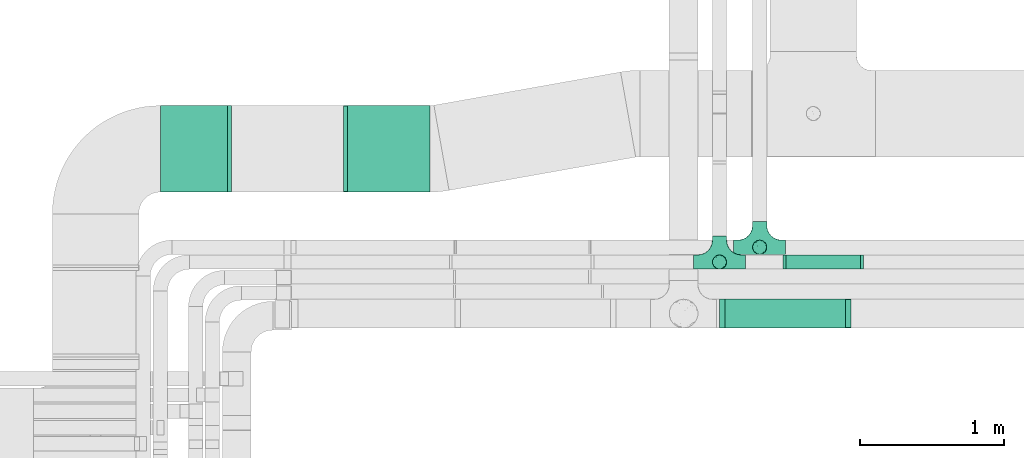
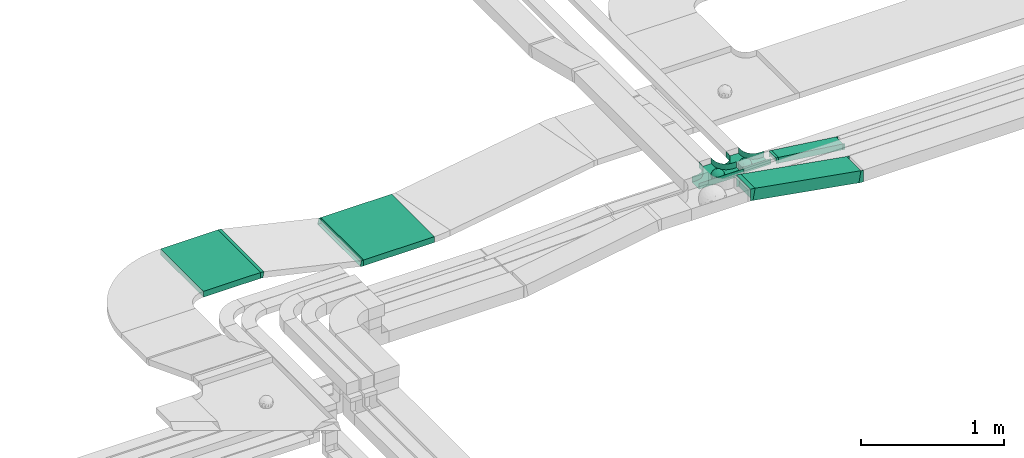
# One storey, part 9 of 28: 8 flow fittings, 4 flow segments.
"""IFC2X3 building model written with IfcOpenShell, lengths in millimetres."""

from ifc_helpers import new_model, entity, si_unit, converted_unit, derived_unit, direction, frame, frame_2d, origin, origin_2d_with_axis, place, context, subcontext, project, spatial, rectangle, extrude, faceted_brep, source, transform, mapped, material, material_list, type_object, type_shapes, element, save


model = new_model("IFC2X3")

# Units and contexts
model_context = context("Model", 3, precision=0.01, world=origin(), true_north=direction((6.12303176911189e-17, 1.0)))
body_context = subcontext(model_context, "Body", "Model", "MODEL_VIEW")
ifc_project = project(units=[si_unit("LENGTHUNIT", "METRE", prefix="MILLI"), si_unit("AREAUNIT", "SQUARE_METRE"), si_unit("VOLUMEUNIT", "CUBIC_METRE"), converted_unit("PLANEANGLEUNIT", "DEGREE", entity("IfcRatioMeasure", 0.0174532925199433), si_unit("PLANEANGLEUNIT", "RADIAN"), dimensions=[0, 0, 0, 0, 0, 0, 0]), si_unit("MASSUNIT", "GRAM", prefix="KILO"), derived_unit("MASSDENSITYUNIT", [(si_unit("MASSUNIT", "GRAM", prefix="KILO"), 1), (si_unit("LENGTHUNIT", "METRE"), -3)]), derived_unit("MOMENTOFINERTIAUNIT", [(si_unit("LENGTHUNIT", "METRE"), 4)]), si_unit("TIMEUNIT", "SECOND"), si_unit("FREQUENCYUNIT", "HERTZ"), si_unit("THERMODYNAMICTEMPERATUREUNIT", "DEGREE_CELSIUS"), derived_unit("THERMALTRANSMITTANCEUNIT", [(si_unit("MASSUNIT", "GRAM", prefix="KILO"), 1), (si_unit("THERMODYNAMICTEMPERATUREUNIT", "KELVIN"), -1), (si_unit("TIMEUNIT", "SECOND"), -3)]), derived_unit("VOLUMETRICFLOWRATEUNIT", [(si_unit("LENGTHUNIT", "METRE"), 3), (si_unit("TIMEUNIT", "SECOND"), -1)]), derived_unit("MASSFLOWRATEUNIT", [(si_unit("MASSUNIT", "GRAM", prefix="KILO"), 1), (si_unit("TIMEUNIT", "SECOND"), -1)]), derived_unit("ROTATIONALFREQUENCYUNIT", [(si_unit("TIMEUNIT", "SECOND"), -1)]), si_unit("ELECTRICCURRENTUNIT", "AMPERE"), si_unit("ELECTRICVOLTAGEUNIT", "VOLT"), si_unit("POWERUNIT", "WATT"), si_unit("FORCEUNIT", "NEWTON", prefix="KILO"), si_unit("ILLUMINANCEUNIT", "LUX"), si_unit("LUMINOUSFLUXUNIT", "LUMEN"), si_unit("LUMINOUSINTENSITYUNIT", "CANDELA"), derived_unit("USERDEFINED", [(si_unit("MASSUNIT", "GRAM", prefix="KILO"), -1), (si_unit("LENGTHUNIT", "METRE"), -2), (si_unit("TIMEUNIT", "SECOND"), 3), (si_unit("LUMINOUSFLUXUNIT", "LUMEN"), 1)]), derived_unit("LINEARVELOCITYUNIT", [(si_unit("LENGTHUNIT", "METRE"), 1), (si_unit("TIMEUNIT", "SECOND"), -1)]), si_unit("PRESSUREUNIT", "PASCAL"), derived_unit("USERDEFINED", [(si_unit("LENGTHUNIT", "METRE"), -2), (si_unit("MASSUNIT", "GRAM", prefix="KILO"), 1), (si_unit("TIMEUNIT", "SECOND"), -2)]), derived_unit("LINEARFORCEUNIT", [(si_unit("MASSUNIT", "GRAM", prefix="KILO"), 1), (si_unit("LENGTHUNIT", "METRE"), 1), (si_unit("TIMEUNIT", "SECOND"), -2), (si_unit("LENGTHUNIT", "METRE"), -1)]), derived_unit("PLANARFORCEUNIT", [(si_unit("MASSUNIT", "GRAM", prefix="KILO"), 1), (si_unit("LENGTHUNIT", "METRE"), 1), (si_unit("TIMEUNIT", "SECOND"), -2), (si_unit("LENGTHUNIT", "METRE"), -2)])], contexts=[model_context])

# Site, building, storey
site_placement = place(None, origin())
site = spatial("IfcSite", under=ifc_project, at=site_placement, CompositionType="ELEMENT")
building_placement = place(site_placement, origin())
building = spatial("IfcBuilding", under=site, at=building_placement, CompositionType="ELEMENT")
storey_placement = place(building_placement, frame((0.0, 0.0, 4200.0)))
storey = spatial("IfcBuildingStorey", under=building, at=storey_placement, CompositionType="ELEMENT", Elevation=4200.0)

# Flow segments
cable_carrier_segment_type = type_object("IfcCableCarrierSegmentType", PredefinedType="CABLETRAYSEGMENT")
flow_segment_1_placement = place(storey_placement, frame((14852.36, 11443.79, 2753.16)))
element("IfcFlowSegment", 1, at=flow_segment_1_placement, inside=storey, type_object=cable_carrier_segment_type, context=body_context, shape_type="SweptSolid", body=[
    extrude(rectangle(XDim=100.000000000001, YDim=200.000000000002, at=frame_2d((0.0, 0.0), x_axis=(0.0, 1.0))), frame((8.59, 100.0, 198.48), z_axis=(0.985142848049724, 0.0, -0.171736917803013), x_axis=(0.0, 1.0, 0.0)), (0.0, 0.0, 1.0), 868.89030102402),
])
flow_segment_2_placement = place(storey_placement, frame((15288.05, 11851.53, 2751.31)))
element("IfcFlowSegment", 2, at=flow_segment_2_placement, inside=storey, type_object=cable_carrier_segment_type, context=body_context, shape_type="SweptSolid", body=[
    extrude(rectangle(XDim=50.0000000000006, YDim=99.9999999999989, at=origin_2d_with_axis()), frame((3.21, 50.0, 92.6), z_axis=(0.991711012567267, 0.0, -0.128488394623039), x_axis=(0.128488394623039, 0.0, 0.991711012567267)), (0.0, 0.0, 1.0), 527.700012402662),
])
flow_segment_3_placement = place(storey_placement, frame((10954.59, 12387.05, 2868.06)))
element("IfcFlowSegment", 3, at=flow_segment_3_placement, inside=storey, type_object=cable_carrier_segment_type, context=body_context, shape_type="SweptSolid", body=[
    extrude(rectangle(XDim=463.236536668238, YDim=600.000000000002, at=origin_2d_with_axis()), frame((231.62, 300.0, 0.0)), (0.0, 0.0, 1.0), 49.9999999999995),
])
flow_segment_4_placement = place(storey_placement, frame((12250.0, 12387.05, 2682.77)))
element("IfcFlowSegment", 4, at=flow_segment_4_placement, inside=storey, type_object=cable_carrier_segment_type, context=body_context, shape_type="SweptSolid", body=[
    extrude(rectangle(XDim=572.823035820443, YDim=600.000000000002, at=origin_2d_with_axis()), frame((286.41, 300.0, 0.0), z_axis=(0.0, 0.0, 1.0), x_axis=(-1.0, 0.0, 0.0)), (0.0, 0.0, 1.0), 49.9999999999995),
])

# Flow fittings
ifc_material_1 = material()
ifc_material_2 = material()
ifc_material_list = material_list([ifc_material_1, ifc_material_2])
cable_carrier_fitting_type_1 = type_object("IfcCableCarrierFittingType", PredefinedType="NOTDEFINED", material=ifc_material_1)
shared_shape_1 = source(origin(), body_context, "Body", "Brep", [
    faceted_brep([(43.65, -13.62, -20.22), (44.77, 0.0, -22.26), (48.26, -5.6, -11.81), (16.66, 5.33, -46.84), (11.56, -8.33, -47.93), (2.02, 2.7, -49.89), (-7.81, -35.95, -33.86), (-17.21, -38.27, -27.19), (-11.13, -27.32, -40.37), (37.7, -7.25, -32.03), (10.64, 26.52, -41.03), (19.21, 19.84, -41.68), (10.42, 17.81, -45.54), (48.75, 0.0, 0.0), (48.07, 6.52, -12.13), (-37.46, 12.16, -30.81), (-31.35, 12.15, -37.01), (-38.09, 3.52, -32.2), (48.75, 11.13, 0.0), (9.67, 42.57, -24.39), (17.48, 37.97, -27.43), (8.35, 35.36, -34.35), (36.7, 20.43, -27.12), (28.22, 12.58, -39.31), (28.4, 24.01, -33.43), (37.1, 7.75, -32.61), (30.39, 38.11, 0.0), (34.74, 34.64, 0.0), (32.94, 32.13, -19.56), (26.04, 41.58, 0.0), (-44.77, 0.0, -22.26), (-35.92, -8.72, -33.67), (-42.7, -12.19, -22.99), (5.42, -48.76, 0.0), (0.0, -48.78, -10.96), (7.59, -47.43, -13.88), (34.0, -31.65, -18.51), (40.01, -26.24, -14.51), (30.39, -38.11, 0.0), (-47.55, -8.65, -12.8), (43.92, -21.15, 0.0), (-47.55, 8.68, -12.81), (-43.92, 21.15, 0.0), (-41.56, 23.54, -14.78), (-36.7, 20.43, -27.12), (-42.68, 12.16, -23.03), (-0.04, -44.68, -22.44), (43.35, 13.13, -21.19), (-9.67, -42.82, -23.94), (2.93, -38.3, -32.0), (10.58, -32.36, -36.62), (17.48, -37.97, -27.43), (29.42, -14.29, -37.82), (29.26, 0.0, -40.54), (-34.74, 34.64, 0.0), (-35.59, 30.87, -16.74), (16.27, 46.29, 0.0), (15.4, 45.37, -14.3), (10.85, 47.52, 0.0), (-22.09, 42.26, -15.04), (-16.27, 46.29, 0.0), (-15.4, 45.37, -14.3), (-35.57, -30.88, -16.76), (-34.74, -34.64, 0.0), (-41.54, -23.57, -14.78), (-21.2, -29.91, -34.0), (-22.09, -42.26, -15.04), (-28.59, -35.77, -20.07), (27.97, -26.92, -31.51), (26.56, -36.75, -21.06), (-4.7, -12.82, -48.1), (-3.71, -22.05, -44.72), (0.0, -29.85, -40.11), (-8.78, 23.47, -43.27), (-10.71, 12.15, -47.3), (-19.19, 19.81, -41.71), (19.21, -19.84, -41.68), (10.27, -43.25, -22.88), (-16.27, -46.29, 0.0), (-15.42, -45.43, -14.08), (-10.85, -47.52, 0.0), (-21.69, -45.05, 0.0), (-26.04, -41.58, 0.0), (-30.39, -38.11, 0.0), (-26.91, -11.71, -40.48), (-28.57, -22.53, -34.29), (-14.35, 0.55, -47.89), (20.39, 29.7, -34.67), (25.88, 35.56, -23.78), (-1.9, 38.3, -32.09), (-0.04, 44.68, -22.44), (-9.54, 42.67, -24.26), (-10.12, 33.04, -36.14), (-17.21, 38.27, -27.19), (-28.59, 35.77, -20.07), (-30.39, 38.11, 0.0), (-26.04, 41.58, 0.0), (-21.69, 45.05, 0.0), (0.92, 16.99, -47.01), (0.0, 29.85, -40.11), (-28.43, 23.64, -33.66), (22.08, -42.72, -13.7), (0.0, -50.0, 0.0), (-7.98, 47.29, -14.15), (-10.85, 47.52, 0.0), (-5.42, 48.76, 0.0), (-39.09, -31.17, 0.0), (-36.7, -20.43, -27.12), (-20.05, 29.88, -34.71), (48.75, -11.13, 0.0), (36.7, -20.43, -27.12), (39.09, -31.17, 0.0), (43.92, 21.15, 0.0), (41.04, 24.48, -14.72), (21.43, -9.87, -44.08), (19.85, -30.3, -34.47), (26.04, -41.58, 0.0), (8.28, -22.62, -43.82), (-19.19, -19.81, -41.71), (-17.56, -9.66, -45.81), (-29.26, 0.0, -40.54), (-22.28, 8.45, -43.96), (21.69, -45.05, 0.0), (-7.75, -47.32, -14.15), (22.09, 42.36, -14.75), (21.69, 45.05, 0.0), (7.94, 47.25, -14.29), (5.42, 48.76, 0.0), (-43.92, -21.15, 0.0), (-39.09, 31.17, 0.0), (-48.75, 11.13, 0.0), (-48.75, -11.13, 0.0), (-48.75, 0.0, 0.0), (0.0, 50.0, 0.0), (0.0, 48.77, -11.04), (-5.42, -48.76, 0.0), (16.27, -46.29, 0.0), (10.85, -47.52, 0.0), (39.09, 31.17, 0.0), (34.74, -34.64, 0.0), (-43.65, -13.62, 20.22), (-44.77, 0.0, 22.26), (-48.26, -5.6, 11.81), (-16.66, 5.33, 46.84), (-11.56, -8.33, 47.93), (-2.02, 2.7, 49.89), (7.81, -35.95, 33.86), (17.21, -38.27, 27.19), (11.13, -27.32, 40.37), (-37.7, -7.25, 32.03), (-10.64, 26.52, 41.03), (-19.21, 19.84, 41.68), (-10.42, 17.81, 45.54), (-48.07, 6.52, 12.13), (37.46, 12.16, 30.81), (31.35, 12.15, 37.01), (38.09, 3.52, 32.2), (-9.67, 42.57, 24.39), (-17.48, 37.97, 27.43), (-8.35, 35.36, 34.35), (-36.7, 20.43, 27.12), (-28.22, 12.58, 39.31), (-28.4, 24.01, 33.43), (-37.1, 7.75, 32.61), (-32.94, 32.13, 19.56), (44.77, 0.0, 22.26), (35.92, -8.72, 33.67), (42.7, -12.19, 22.99), (0.0, -48.78, 10.96), (-7.59, -47.43, 13.88), (-34.0, -31.65, 18.51), (-40.01, -26.24, 14.51), (47.55, -8.65, 12.8), (47.55, 8.68, 12.81), (41.56, 23.54, 14.78), (36.7, 20.43, 27.12), (42.68, 12.16, 23.03), (0.04, -44.68, 22.44), (-43.35, 13.13, 21.19), (9.67, -42.82, 23.94), (-2.93, -38.3, 32.0), (-10.58, -32.36, 36.62), (-17.48, -37.97, 27.43), (-29.42, -14.29, 37.82), (-29.26, 0.0, 40.54), (35.59, 30.87, 16.74), (-15.4, 45.37, 14.3), (22.09, 42.26, 15.04), (15.4, 45.37, 14.3), (35.57, -30.88, 16.76), (41.54, -23.57, 14.78), (21.2, -29.91, 34.0), (22.09, -42.26, 15.04), (28.59, -35.77, 20.07), (-27.97, -26.92, 31.51), (-26.56, -36.75, 21.06), (4.7, -12.82, 48.1), (3.71, -22.05, 44.72), (0.0, -29.85, 40.11), (8.78, 23.47, 43.27), (10.71, 12.15, 47.3), (19.19, 19.81, 41.71), (-19.21, -19.84, 41.68), (-10.27, -43.25, 22.88), (15.42, -45.43, 14.08), (26.91, -11.71, 40.48), (28.57, -22.53, 34.29), (14.35, 0.55, 47.89), (-20.39, 29.7, 34.67), (-25.88, 35.56, 23.78), (1.9, 38.3, 32.09), (0.04, 44.68, 22.44), (9.54, 42.67, 24.26), (10.12, 33.04, 36.14), (17.21, 38.27, 27.19), (28.59, 35.77, 20.07), (-0.92, 16.99, 47.01), (0.0, 29.85, 40.11), (28.43, 23.64, 33.66), (-22.08, -42.72, 13.7), (7.98, 47.29, 14.15), (36.7, -20.43, 27.12), (20.05, 29.88, 34.71), (-36.7, -20.43, 27.12), (-41.04, 24.48, 14.72), (-21.43, -9.87, 44.08), (-19.85, -30.3, 34.47), (-8.28, -22.62, 43.82), (19.19, -19.81, 41.71), (17.56, -9.66, 45.81), (29.26, 0.0, 40.54), (22.28, 8.45, 43.96), (7.75, -47.32, 14.15), (-22.09, 42.36, 14.75), (-7.94, 47.25, 14.29), (0.0, 48.77, 11.04)], [[[0, 1, 2]], [[3, 4, 5]], [[6, 7, 8]], [[1, 0, 9]], [[10, 11, 12]], [[13, 2, 14]], [[15, 16, 17]], [[14, 18, 13]], [[19, 20, 21]], [[22, 23, 24]], [[1, 9, 25]], [[26, 27, 28, 29]], [[30, 31, 32]], [[33, 34, 35]], [[36, 37, 38]], [[32, 39, 30]], [[2, 40, 0]], [[23, 22, 25]], [[41, 42, 43]], [[44, 15, 45]], [[46, 35, 34]], [[25, 22, 47]], [[31, 30, 17]], [[48, 49, 46]], [[50, 51, 49]], [[52, 53, 9]], [[43, 54, 55]], [[56, 57, 58]], [[59, 60, 61]], [[62, 63, 64]], [[8, 7, 65]], [[7, 66, 67]], [[68, 36, 69]], [[70, 5, 4]], [[8, 71, 72]], [[73, 74, 75]], [[68, 76, 52]], [[77, 46, 49]], [[78, 79, 80]], [[7, 6, 48]], [[67, 81, 82, 83]], [[84, 85, 31]], [[85, 65, 67]], [[70, 86, 5]], [[23, 3, 11]], [[21, 87, 10]], [[21, 20, 87]], [[28, 24, 88]], [[19, 89, 90]], [[91, 90, 89]], [[91, 92, 93]], [[94, 95, 96, 97]], [[98, 99, 10]], [[100, 16, 44]], [[77, 51, 101]], [[33, 102, 34]], [[103, 91, 61]], [[93, 59, 61]], [[104, 105, 103]], [[106, 64, 63]], [[107, 31, 85]], [[100, 94, 108]], [[108, 93, 92]], [[43, 55, 44]], [[0, 40, 37]], [[2, 13, 109]], [[2, 1, 14]], [[110, 9, 0]], [[2, 109, 40]], [[37, 40, 111]], [[47, 14, 1]], [[112, 14, 47]], [[113, 112, 47]], [[112, 18, 14]], [[47, 22, 113]], [[52, 9, 110]], [[53, 25, 9]], [[25, 47, 1]], [[23, 25, 53]], [[68, 52, 110]], [[76, 4, 114]], [[51, 115, 69]], [[50, 115, 51]], [[110, 36, 68]], [[3, 23, 53]], [[23, 11, 24]], [[52, 76, 114]], [[98, 12, 5]], [[11, 87, 24]], [[24, 28, 22]], [[87, 88, 24]], [[36, 116, 69]], [[28, 27, 113]], [[114, 3, 53]], [[76, 115, 117]], [[70, 4, 117]], [[118, 84, 119]], [[119, 70, 118]], [[120, 16, 121]], [[37, 36, 110]], [[116, 36, 38]], [[116, 122, 69]], [[34, 123, 46]], [[10, 87, 11]], [[87, 20, 88]], [[12, 98, 10]], [[10, 99, 21]], [[74, 5, 86]], [[73, 75, 108]], [[124, 56, 125]], [[124, 29, 88]], [[89, 21, 99]], [[21, 89, 19]], [[92, 89, 99]], [[89, 92, 91]], [[126, 127, 58]], [[88, 29, 28]], [[20, 57, 124]], [[88, 20, 124]], [[57, 20, 19]], [[73, 92, 99]], [[92, 73, 108]], [[99, 98, 73]], [[74, 86, 121]], [[73, 98, 74]], [[5, 74, 98]], [[100, 108, 75]], [[94, 93, 108]], [[86, 120, 121]], [[100, 44, 55]], [[75, 16, 100]], [[17, 16, 120]], [[31, 17, 120]], [[17, 30, 45]], [[84, 31, 120]], [[31, 107, 32]], [[41, 45, 30]], [[43, 44, 45]], [[107, 64, 32]], [[39, 64, 128]], [[30, 39, 41]], [[129, 43, 42]], [[41, 130, 42]], [[43, 45, 41]], [[62, 83, 63]], [[95, 94, 55]], [[100, 55, 94]], [[64, 107, 62]], [[131, 39, 128]], [[64, 106, 128]], [[85, 62, 107]], [[67, 83, 62]], [[39, 32, 64]], [[130, 41, 132]], [[59, 97, 60]], [[133, 127, 134]], [[59, 94, 97]], [[104, 61, 60]], [[94, 59, 93]], [[126, 134, 127]], [[126, 58, 57]], [[19, 90, 126]], [[134, 105, 133]], [[126, 90, 134]], [[103, 90, 91]], [[105, 134, 103]], [[90, 103, 134]], [[119, 120, 86]], [[84, 118, 85]], [[65, 85, 118]], [[62, 85, 67]], [[8, 65, 118]], [[67, 65, 7]], [[71, 118, 70]], [[8, 72, 6]], [[49, 6, 72]], [[6, 49, 48]], [[50, 49, 72]], [[77, 49, 51]], [[101, 69, 122]], [[123, 34, 135]], [[101, 122, 136]], [[137, 77, 136]], [[78, 81, 66]], [[7, 79, 66]], [[67, 66, 81]], [[79, 7, 48]], [[35, 137, 33]], [[123, 80, 79]], [[135, 34, 102]], [[35, 46, 77]], [[80, 123, 135]], [[46, 123, 48]], [[117, 50, 72]], [[115, 76, 68]], [[117, 72, 71]], [[4, 76, 117]], [[39, 132, 41]], [[39, 131, 132]], [[137, 35, 77]], [[124, 57, 56]], [[126, 57, 19]], [[103, 61, 104]], [[61, 91, 93]], [[77, 101, 136]], [[51, 69, 101]], [[28, 113, 22]], [[112, 113, 138]], [[16, 75, 121]], [[74, 121, 75]], [[66, 79, 78]], [[123, 79, 48]], [[0, 37, 110]], [[37, 111, 139, 38]], [[29, 124, 125]], [[115, 50, 117]], [[69, 115, 68]], [[120, 119, 84]], [[70, 119, 86]], [[11, 3, 12]], [[5, 12, 3]], [[118, 71, 8]], [[117, 71, 70]], [[3, 114, 4]], [[53, 52, 114]], [[27, 138, 113]], [[45, 15, 17]], [[44, 16, 15]], [[55, 54, 95]], [[43, 129, 54]], [[140, 141, 142]], [[143, 144, 145]], [[146, 147, 148]], [[141, 140, 149]], [[150, 151, 152]], [[132, 142, 153]], [[154, 155, 156]], [[153, 130, 132]], [[157, 158, 159]], [[160, 161, 162]], [[141, 149, 163]], [[95, 54, 164, 96]], [[165, 166, 167]], [[135, 168, 169]], [[170, 171, 83]], [[167, 172, 165]], [[142, 141, 153]], [[161, 160, 163]], [[173, 112, 174]], [[175, 154, 176]], [[177, 169, 168]], [[163, 160, 178]], [[166, 165, 156]], [[179, 180, 177]], [[181, 182, 180]], [[183, 184, 149]], [[174, 27, 185]], [[60, 186, 104]], [[187, 56, 188]], [[189, 139, 190]], [[148, 147, 191]], [[147, 192, 193]], [[194, 170, 195]], [[196, 145, 144]], [[148, 197, 198]], [[199, 200, 201]], [[194, 202, 183]], [[203, 177, 180]], [[136, 204, 137]], [[147, 146, 179]], [[193, 122, 116, 38]], [[205, 206, 166]], [[206, 191, 193]], [[196, 207, 145]], [[161, 143, 151]], [[159, 208, 150]], [[159, 158, 208]], [[164, 162, 209]], [[157, 210, 211]], [[212, 211, 210]], [[212, 213, 214]], [[215, 26, 29, 125]], [[216, 217, 150]], [[218, 155, 175]], [[203, 182, 219]], [[135, 102, 168]], [[220, 212, 188]], [[214, 187, 188]], [[58, 127, 220]], [[111, 190, 139]], [[221, 166, 206]], [[218, 215, 222]], [[222, 214, 213]], [[174, 185, 175]], [[171, 140, 128]], [[132, 131, 142]], [[142, 128, 140]], [[223, 149, 140]], [[142, 131, 128]], [[171, 128, 106]], [[178, 153, 141]], [[42, 153, 178]], [[224, 42, 178]], [[42, 130, 153]], [[178, 160, 224]], [[183, 149, 223]], [[184, 163, 149]], [[163, 178, 141]], [[161, 163, 184]], [[194, 183, 223]], [[202, 144, 225]], [[182, 226, 195]], [[181, 226, 182]], [[223, 170, 194]], [[143, 161, 184]], [[161, 151, 162]], [[183, 202, 225]], [[216, 152, 145]], [[151, 208, 162]], [[162, 164, 160]], [[208, 209, 162]], [[170, 82, 195]], [[164, 54, 224]], [[225, 143, 184]], [[202, 226, 227]], [[196, 144, 227]], [[228, 205, 229]], [[229, 196, 228]], [[230, 155, 231]], [[171, 170, 223]], [[82, 170, 83]], [[82, 81, 195]], [[168, 232, 177]], [[150, 208, 151]], [[208, 158, 209]], [[152, 216, 150]], [[150, 217, 159]], [[200, 145, 207]], [[199, 201, 222]], [[233, 60, 97]], [[233, 96, 209]], [[210, 159, 217]], [[159, 210, 157]], [[213, 210, 217]], [[210, 213, 212]], [[234, 105, 104]], [[209, 96, 164]], [[158, 186, 233]], [[209, 158, 233]], [[186, 158, 157]], [[199, 213, 217]], [[213, 199, 222]], [[217, 216, 199]], [[200, 207, 231]], [[199, 216, 200]], [[145, 200, 216]], [[218, 222, 201]], [[215, 214, 222]], [[207, 230, 231]], [[218, 175, 185]], [[201, 155, 218]], [[156, 155, 230]], [[166, 156, 230]], [[156, 165, 176]], [[205, 166, 230]], [[166, 221, 167]], [[173, 176, 165]], [[174, 175, 176]], [[221, 190, 167]], [[172, 190, 40]], [[165, 172, 173]], [[138, 174, 112]], [[173, 18, 112]], [[174, 176, 173]], [[189, 38, 139]], [[26, 215, 185]], [[218, 185, 215]], [[190, 221, 189]], [[109, 172, 40]], [[190, 111, 40]], [[206, 189, 221]], [[193, 38, 189]], [[172, 167, 190]], [[18, 173, 13]], [[187, 125, 56]], [[133, 105, 235]], [[187, 215, 125]], [[58, 188, 56]], [[215, 187, 214]], [[234, 235, 105]], [[234, 104, 186]], [[157, 211, 234]], [[235, 127, 133]], [[234, 211, 235]], [[220, 211, 212]], [[127, 235, 220]], [[211, 220, 235]], [[229, 230, 207]], [[205, 228, 206]], [[191, 206, 228]], [[189, 206, 193]], [[148, 191, 228]], [[193, 191, 147]], [[197, 228, 196]], [[148, 198, 146]], [[180, 146, 198]], [[146, 180, 179]], [[181, 180, 198]], [[203, 180, 182]], [[219, 195, 81]], [[232, 168, 33]], [[219, 81, 78]], [[80, 203, 78]], [[136, 122, 192]], [[147, 204, 192]], [[193, 192, 122]], [[204, 147, 179]], [[169, 80, 135]], [[232, 137, 204]], [[33, 168, 102]], [[169, 177, 203]], [[137, 232, 33]], [[177, 232, 179]], [[227, 181, 198]], [[226, 202, 194]], [[227, 198, 197]], [[144, 202, 227]], [[172, 13, 173]], [[172, 109, 13]], [[80, 169, 203]], [[233, 186, 60]], [[234, 186, 157]], [[220, 188, 58]], [[188, 212, 214]], [[203, 219, 78]], [[182, 195, 219]], [[164, 224, 160]], [[42, 224, 129]], [[155, 201, 231]], [[200, 231, 201]], [[192, 204, 136]], [[232, 204, 179]], [[140, 171, 223]], [[171, 106, 63, 83]], [[96, 233, 97]], [[226, 181, 227]], [[195, 226, 194]], [[230, 229, 205]], [[196, 229, 207]], [[151, 143, 152]], [[145, 152, 143]], [[228, 197, 148]], [[227, 197, 196]], [[143, 225, 144]], [[184, 183, 225]], [[54, 129, 224]], [[176, 154, 156]], [[175, 155, 154]], [[185, 27, 26]], [[174, 138, 27]]]),
    faceted_brep([(-53.41, -124.12, 25.0), (-50.0, -150.0, 25.0), (-50.0, -180.0, 25.0), (-49.2, -180.0, 25.0), (-49.2, -150.0, 25.0), (-52.63, -123.91, 25.0), (-62.7, -99.6, 25.0), (-78.72, -78.72, 25.0), (-99.6, -62.7, 25.0), (-123.91, -52.63, 25.0), (-150.0, -49.2, 25.0), (-180.0, -49.2, 25.0), (-180.0, -50.0, 25.0), (-150.0, -50.0, 25.0), (-124.12, -53.41, 25.0), (-100.0, -63.4, 25.0), (-79.29, -79.29, 25.0), (-63.4, -100.0, 25.0), (180.0, -50.0, 25.0), (180.0, -49.2, 25.0), (150.0, -49.2, 25.0), (123.91, -52.63, 25.0), (99.6, -62.7, 25.0), (78.72, -78.72, 25.0), (62.7, -99.6, 25.0), (52.63, -123.91, 25.0), (49.2, -150.0, 25.0), (49.2, -180.0, 25.0), (50.0, -180.0, 25.0), (50.0, -150.0, 25.0), (53.41, -124.12, 25.0), (63.4, -100.0, 25.0), (79.29, -79.29, 25.0), (100.0, -63.4, 25.0), (124.12, -53.41, 25.0), (150.0, -50.0, 25.0), (180.0, 49.2, 25.0), (180.0, 50.0, 25.0), (-180.0, 50.0, 25.0), (-180.0, 49.2, 25.0), (-180.0, -50.0, -25.0), (-180.0, 50.0, -25.0), (180.0, 50.0, -25.0), (180.0, -50.0, -25.0), (150.0, -50.0, -25.0), (124.12, -53.41, -25.0), (100.0, -63.4, -25.0), (79.29, -79.29, -25.0), (63.4, -100.0, -25.0), (53.41, -124.12, -25.0), (50.0, -150.0, -25.0), (50.0, -180.0, -25.0), (-50.0, -180.0, -25.0), (-50.0, -150.0, -25.0), (-53.41, -124.12, -25.0), (-63.4, -100.0, -25.0), (-79.29, -79.29, -25.0), (-100.0, -63.4, -25.0), (-124.12, -53.41, -25.0), (-150.0, -50.0, -25.0), (-50.0, -150.0, -24.2), (49.2, -180.0, -24.2), (-49.2, -180.0, -24.2), (-49.2, -150.0, -24.2), (-150.0, -49.2, -24.2), (-180.0, -49.2, -24.2), (180.0, -49.2, -24.2), (150.0, -49.2, -24.2), (-180.0, 49.2, -24.2), (-150.0, -50.0, -24.2), (150.0, -50.0, -24.2), (180.0, 49.2, -24.2), (49.2, -150.0, -24.2), (50.0, -150.0, -24.2), (-123.91, -52.63, -24.2), (-99.6, -62.7, -24.2), (-78.72, -78.72, -24.2), (-62.7, -99.6, -24.2), (-52.63, -123.91, -24.2), (52.63, -123.91, -24.2), (62.7, -99.6, -24.2), (78.72, -78.72, -24.2), (99.6, -62.7, -24.2), (123.91, -52.63, -24.2)], [[[0, 1, 2, 3, 4, 5, 6, 7, 8, 9, 10, 11, 12, 13, 14, 15, 16, 17]], [[18, 19, 20, 21, 22, 23, 24, 25, 26, 27, 28, 29, 30, 31, 32, 33, 34, 35]], [[36, 37, 38, 39]], [[40, 41, 42, 43, 44, 45, 46, 47, 48, 49, 50, 51, 52, 53, 54, 55, 56, 57, 58, 59]], [[2, 1, 60, 53, 52]], [[3, 2, 52, 51, 28, 27, 61, 62]], [[4, 3, 62, 63]], [[11, 10, 64, 65]], [[20, 19, 66, 67]], [[39, 38, 41, 40, 12, 11, 65, 68]], [[13, 12, 40, 59, 69]], [[18, 35, 70, 44, 43]], [[19, 18, 43, 42, 37, 36, 71, 66]], [[27, 26, 72, 61]], [[29, 28, 51, 50, 73]], [[38, 37, 42, 41]], [[36, 39, 68, 71]], [[68, 65, 64, 74, 75, 76, 77, 78, 63, 62, 61, 72, 79, 80, 81, 82, 83, 67, 66, 71]], [[14, 13, 69, 59, 58]], [[58, 57, 15, 14]], [[15, 57, 56, 16]], [[0, 17, 55, 54]], [[0, 54, 53, 60, 1]], [[55, 17, 16, 56]], [[5, 4, 63, 78]], [[6, 5, 78, 77]], [[7, 6, 77, 76]], [[8, 7, 76, 75]], [[9, 8, 75, 74]], [[10, 9, 74, 64]], [[21, 20, 67, 83]], [[22, 21, 83, 82]], [[23, 22, 82, 81]], [[81, 80, 24, 23]], [[24, 80, 79, 25]], [[79, 72, 26, 25]], [[30, 29, 73, 50, 49]], [[31, 30, 49, 48]], [[31, 48, 47, 32]], [[33, 32, 47, 46]], [[45, 34, 33, 46]], [[34, 45, 44, 70, 35]]]),
])
type_shapes(cable_carrier_fitting_type_1, [shared_shape_1])
for number, where, z_axis, x_axis, name in (
    (5, (15111.77, 12004.03, 2775.0), (0.0, 0.0, 1.0), (-1.0, 0.0, 0.0), "470_DKC_S5_T"),
    (6, (14833.07, 11901.53, 2845.0), (0.0, 0.0, 1.0), (-1.0, 0.0, 0.0), "470_DKC_S5_T"),
):
    element("IfcFlowFitting", number, at=place(storey_placement, frame(where, z_axis=z_axis, x_axis=x_axis)), inside=storey, type_object=cable_carrier_fitting_type_1, material=ifc_material_list, Name=name, context=body_context, shape_type="MappedRepresentation", body=[
        mapped(shared_shape_1, transform((0.0, 0.0, 0.0), scale=1.0)),
    ])
cable_carrier_fitting_type_2 = type_object("IfcCableCarrierFittingType", PredefinedType="NOTDEFINED", material=ifc_material_2)
shared_shape_2 = source(origin(), body_context, "Body", "Brep", [
    faceted_brep([(-14.08, -50.0, 100.0), (-14.08, 50.0, 100.0), (-14.08, 50.0, 97.46), (-14.08, -47.46, 97.46), (-14.08, -47.46, -97.46), (-14.08, 50.0, -97.46), (-14.08, 50.0, -100.0), (-14.08, -50.0, -100.0), (22.46, -46.84, 100.0), (22.46, -46.84, -100.0), (5.29, 51.68, -100.0), (5.29, 51.68, -97.46), (22.03, -44.34, -97.46), (22.03, -44.34, 97.46), (5.29, 51.68, 97.46), (5.29, 51.68, 100.0), (4.33, -50.0, 100.0), (-4.33, 50.0, 100.0), (-4.33, 50.0, 97.46), (4.11, -47.46, 97.46), (4.11, -47.46, -97.46), (-4.33, 50.0, -97.46), (-4.33, 50.0, -100.0), (4.33, -50.0, -100.0)], [[[0, 1, 2, 3, 4, 5, 6, 7]], [[8, 9, 10, 11, 12, 13, 14, 15]], [[1, 0, 16, 8, 15, 17]], [[2, 1, 17, 18]], [[3, 2, 18, 14, 13, 19]], [[4, 3, 19, 20]], [[5, 4, 20, 12, 11, 21]], [[6, 5, 21, 22]], [[7, 6, 22, 10, 9, 23]], [[0, 7, 23, 16]], [[18, 17, 15, 14]], [[20, 19, 13, 12]], [[22, 21, 11, 10]], [[16, 23, 9, 8]]]),
])
type_shapes(cable_carrier_fitting_type_2, [shared_shape_2])
for number, where, z_axis, x_axis in (
    (7, (14847.08, 11543.79, 2954.06), (0.0, 1.0, 0.0), (1.0, 0.0, 0.0)),
    (8, (15730.81, 11543.79, 2800.0), (0.0, -1.0, 0.0), (0.985142848049724, 0.0, -0.17173691780301)),
):
    element("IfcFlowFitting", number, at=place(storey_placement, frame(where, z_axis=z_axis, x_axis=x_axis)), inside=storey, type_object=cable_carrier_fitting_type_2, material=ifc_material_2, context=body_context, shape_type="MappedRepresentation", body=[
        mapped(shared_shape_2, transform((0.0, 0.0, 0.0), scale=1.0)),
    ])
cable_carrier_fitting_type_3 = type_object("IfcCableCarrierFittingType", PredefinedType="NOTDEFINED", material=ifc_material_2)
shared_shape_3 = source(origin(), body_context, "Body", "Brep", [
    faceted_brep([(-8.55, -25.0, 50.0), (-8.55, 25.0, 50.0), (-8.55, 25.0, 47.46), (-8.55, -22.46, 47.46), (-8.55, -22.46, -47.46), (-8.55, 25.0, -47.46), (-8.55, 25.0, -50.0), (-8.55, -25.0, -50.0), (11.69, -23.69, 50.0), (11.69, -23.69, -50.0), (5.27, 25.89, -50.0), (5.27, 25.89, -47.46), (11.36, -21.18, -47.46), (11.36, -21.18, 47.46), (5.27, 25.89, 47.46), (5.27, 25.89, 50.0), (1.61, -25.0, 50.0), (-1.61, 25.0, 50.0), (-1.61, 25.0, 47.46), (1.45, -22.46, 47.46), (1.45, -22.46, -47.46), (-1.61, 25.0, -47.46), (-1.61, 25.0, -50.0), (1.61, -25.0, -50.0)], [[[0, 1, 2, 3, 4, 5, 6, 7]], [[8, 9, 10, 11, 12, 13, 14, 15]], [[1, 0, 16, 8, 15, 17]], [[2, 1, 17, 18]], [[3, 2, 18, 14, 13, 19]], [[4, 3, 19, 20]], [[5, 4, 20, 12, 11, 21]], [[6, 5, 21, 22]], [[7, 6, 22, 10, 9, 23]], [[0, 7, 23, 16]], [[18, 17, 15, 14]], [[20, 19, 13, 12]], [[22, 21, 11, 10]], [[16, 23, 9, 8]]]),
])
type_shapes(cable_carrier_fitting_type_3, [shared_shape_3])
for number, where, z_axis, x_axis in (
    (9, (15823.07, 11901.53, 2775.0), (0.0, 1.0, 0.0), (-1.0, 0.0, 0.0)),
    (10, (15282.79, 11901.53, 2845.0), (0.0, -1.0, 0.0), (-0.991711012567267, 0.0, 0.128488394623036)),
):
    element("IfcFlowFitting", number, at=place(storey_placement, frame(where, z_axis=z_axis, x_axis=x_axis)), inside=storey, type_object=cable_carrier_fitting_type_3, material=ifc_material_2, context=body_context, shape_type="MappedRepresentation", body=[
        mapped(shared_shape_3, transform((0.0, 0.0, 0.0), scale=1.0)),
    ])
cable_carrier_fitting_type_4 = type_object("IfcCableCarrierFittingType", PredefinedType="NOTDEFINED", material=ifc_material_2)
shared_shape_4 = source(origin(), body_context, "Body", "Brep", [
    faceted_brep([(-11.21, -25.0, 300.0), (-11.21, 25.0, 300.0), (-11.21, 25.0, 297.46), (-11.21, -22.46, 297.46), (-11.21, -22.46, -297.46), (-11.21, 25.0, -297.46), (-11.21, 25.0, -300.0), (-11.21, -25.0, -300.0), (16.51, -21.87, 300.0), (16.51, -21.87, -300.0), (5.35, 26.87, -300.0), (5.35, 26.87, -297.46), (15.94, -19.39, -297.46), (15.94, -19.39, 297.46), (5.35, 26.87, 297.46), (5.35, 26.87, 300.0), (2.82, -25.0, 300.0), (-2.82, 25.0, 300.0), (-2.82, 25.0, 297.46), (2.54, -22.46, 297.46), (2.54, -22.46, -297.46), (-2.82, 25.0, -297.46), (-2.82, 25.0, -300.0), (2.82, -25.0, -300.0)], [[[0, 1, 2, 3, 4, 5, 6, 7]], [[8, 9, 10, 11, 12, 13, 14, 15]], [[1, 0, 16, 8, 15, 17]], [[2, 1, 17, 18]], [[3, 2, 18, 14, 13, 19]], [[4, 3, 19, 20]], [[5, 4, 20, 12, 11, 21]], [[6, 5, 21, 22]], [[7, 6, 22, 10, 9, 23]], [[0, 7, 23, 16]], [[18, 17, 15, 14]], [[20, 19, 13, 12]], [[22, 21, 11, 10]], [[16, 23, 9, 8]]]),
])
type_shapes(cable_carrier_fitting_type_4, [shared_shape_4])
for number, where, z_axis, x_axis in (
    (11, (11429.04, 12687.05, 2893.06), (0.0, 1.0, 0.0), (1.0, 0.0, 0.0)),
    (12, (12238.79, 12687.05, 2707.77), (0.0, 1.0, 0.0), (-1.0, 0.0, 0.0)),
):
    element("IfcFlowFitting", number, at=place(storey_placement, frame(where, z_axis=z_axis, x_axis=x_axis)), inside=storey, type_object=cable_carrier_fitting_type_4, material=ifc_material_2, context=body_context, shape_type="MappedRepresentation", body=[
        mapped(shared_shape_4, transform((0.0, 0.0, 0.0), scale=1.0)),
    ])

save(model, "model.ifc")
